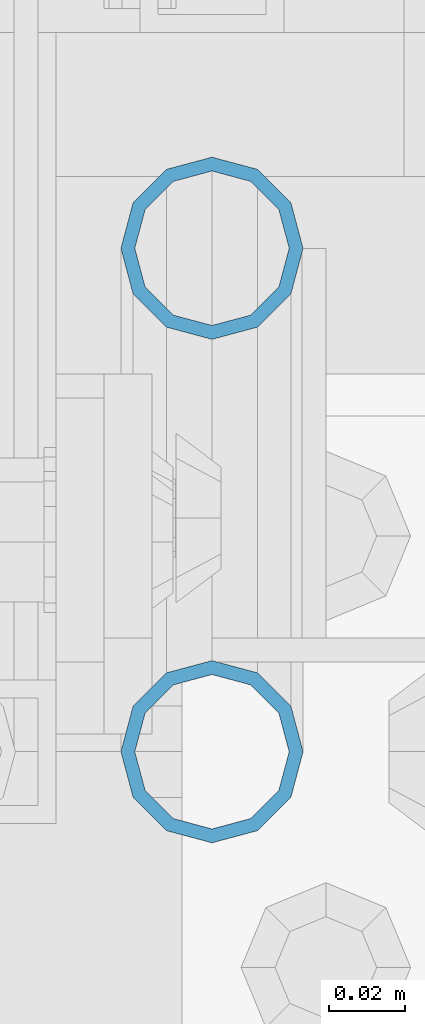
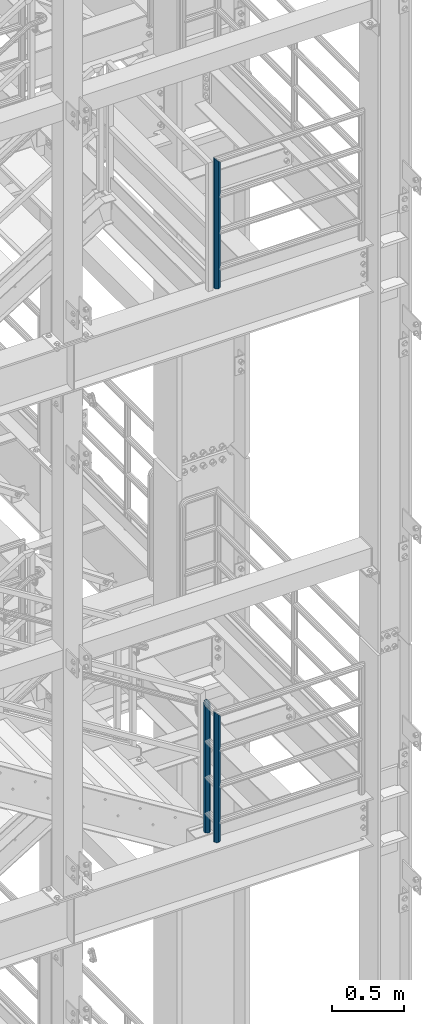
# One storey, part 585 of 1876: 3 columns, 2 elements without a shape of their own.
"""IFC2X3 building model written with IfcOpenShell, lengths in millimetres."""

from ifc_helpers import new_model, si_unit, frame, origin_with_axes, place, context, subcontext, project, spatial, faceted_brep, material, type_object, element, aggregate, save


model = new_model("IFC2X3")

# Units and contexts
model_context = context("Model", 3, precision=1e-05, world=origin_with_axes())
body_context = subcontext(model_context, "Body", "Model", "MODEL_VIEW")
ifc_project = project(units=[si_unit("LENGTHUNIT", "METRE", prefix="MILLI"), si_unit("AREAUNIT", "SQUARE_METRE"), si_unit("VOLUMEUNIT", "CUBIC_METRE"), si_unit("MASSUNIT", "GRAM", prefix="KILO"), si_unit("TIMEUNIT", "SECOND"), si_unit("PLANEANGLEUNIT", "RADIAN"), si_unit("SOLIDANGLEUNIT", "STERADIAN"), si_unit("THERMODYNAMICTEMPERATUREUNIT", "DEGREE_CELSIUS"), si_unit("LUMINOUSINTENSITYUNIT", "LUMEN")], contexts=[model_context])

# Site, building, storey
site_placement = place(None, origin_with_axes())
site = spatial("IfcSite", under=ifc_project, at=site_placement, CompositionType="ELEMENT")
building_placement = place(site_placement, origin_with_axes())
building = spatial("IfcBuilding", under=site, at=building_placement, Name="Undefined", CompositionType="ELEMENT")
storey_placement = place(building_placement, origin_with_axes())
storey = spatial("IfcBuildingStorey", under=building, at=storey_placement, Name="Undefined", CompositionType="ELEMENT", Elevation=0.0)

# Assembly, column
assembly_1_placement = place(storey_placement, origin_with_axes())
assembly_1 = element("IfcElementAssembly", 1, at=assembly_1_placement, inside=storey, Name="RAIL", AssemblyPlace="NOTDEFINED", PredefinedType="RIGID_FRAME")
ifc_material = material()
column_type = type_object("IfcColumnType", Name="PIPE1-1/2SCH40", PredefinedType="NOTDEFINED")
column_1_placement = place(assembly_1_placement, frame((6273.80016410903, -7112.0, 17983.2), z_axis=(0.0, 1.0, 0.0), x_axis=(0.0, 0.0, 1.0)))
column_1 = element("IfcColumn", 2, at=column_1_placement, type_object=column_type, material=ifc_material, Name="POST", ObjectType="PIPE1-1/2SCH40", context=body_context, shape_type="Brep", body=[
    faceted_brep([(0.0, -20.4469999999999, 0.0), (0.0, -17.7076214311803, 10.2235000000001), (1094.03262143118, -17.7076214311804, 10.2235000000001), (1096.772, -20.447, 0.0), (0.0, -10.2235000000001, 17.7076214311801), (1086.5485, -10.2235, 17.7076214311801), (-1.45519152283669e-11, 0.0, 20.4470000000001), (1076.325, 0.0, 20.4470000000001), (0.0, 10.2235000000001, 17.7076214311801), (1066.1015, 10.2235, 17.7076214311801), (0.0, 17.7076214311803, 10.2235000000001), (1058.61737856882, 17.7076214311804, 10.2235000000001), (0.0, 20.4469999999999, 0.0), (1055.878, 20.447, 0.0), (0.0, 17.7076214311803, -10.2235000000001), (1058.61737856882, 17.7076214311804, -10.2235000000001), (0.0, 10.2235000000001, -17.7076214311801), (1066.1015, 10.2235, -17.7076214311801), (-1.45519152283669e-11, 0.0, -20.4470000000001), (1076.325, 0.0, -20.4470000000001), (0.0, -10.2235000000001, -17.7076214311801), (1086.5485, -10.2235, -17.7076214311801), (0.0, -17.7076214311803, -10.2235000000001), (1094.03262143118, -17.7076214311804, -10.2235000000001), (0.0, -24.1299999999992, 0.0), (0.0, -20.8971929933184, -12.0649999999996), (1097.22219299332, -20.8971929933185, -12.0649999999996), (1100.455, -24.13, 0.0), (0.0, -12.0650000000001, -20.8971929933186), (1088.39, -12.065, -20.8971929933186), (-1.45519152283669e-11, 0.0, -24.130000000001), (1076.325, 0.0, -24.1300000000001), (0.0, 12.0650000000001, -20.8971929933186), (1064.26, 12.065, -20.8971929933186), (0.0, 20.8971929933184, -12.0649999999996), (1055.42780700668, 20.8971929933185, -12.0649999999996), (0.0, 24.1299999999992, 0.0), (1052.195, 24.13, 0.0), (0.0, 20.8971929933184, 12.0649999999996), (1055.42780700668, 20.8971929933185, 12.0649999999996), (0.0, 12.0650000000001, 20.8971929933186), (1064.26, 12.065, 20.8971929933186), (-1.45519152283669e-11, 0.0, 24.130000000001), (1076.325, 0.0, 24.1300000000001), (0.0, -12.0650000000001, 20.8971929933186), (1088.39, -12.065, 20.8971929933186), (0.0, -20.8971929933184, 12.0649999999996), (1097.22219299332, -20.8971929933185, 12.0649999999996)], [[[0, 1, 2, 3]], [[1, 4, 5, 2]], [[4, 6, 7, 5]], [[6, 8, 9, 7]], [[8, 10, 11, 9]], [[10, 12, 13, 11]], [[12, 14, 15, 13]], [[14, 16, 17, 15]], [[16, 18, 19, 17]], [[18, 20, 21, 19]], [[20, 22, 23, 21]], [[22, 0, 3, 23]], [[24, 25, 26, 27]], [[25, 28, 29, 26]], [[28, 30, 31, 29]], [[30, 32, 33, 31]], [[32, 34, 35, 33]], [[34, 36, 37, 35]], [[36, 38, 39, 37]], [[38, 40, 41, 39]], [[40, 42, 43, 41]], [[42, 44, 45, 43]], [[44, 46, 47, 45]], [[46, 24, 27, 47]], [[29, 31, 33, 35, 37, 39, 41, 43, 45, 47, 27, 26], [5, 7, 9, 11, 13, 15, 17, 19, 21, 23, 3, 2]], [[46, 44, 42, 40, 38, 36, 34, 32, 30, 28, 25, 24], [22, 20, 18, 16, 14, 12, 10, 8, 6, 4, 1, 0]]]),
])
aggregate(assembly_1, [column_1])

# Assembly, columns
assembly_2_placement = place(storey_placement, origin_with_axes())
assembly_2 = element("IfcElementAssembly", 3, at=assembly_2_placement, inside=storey, Name="RAIL", AssemblyPlace="NOTDEFINED", PredefinedType="RIGID_FRAME")
column_2_placement = place(assembly_2_placement, frame((6273.80016410903, -6978.65, 13309.6), z_axis=(0.0, 1.0, 0.0), x_axis=(0.0, 0.0, 1.0)))
column_2 = element("IfcColumn", 4, at=column_2_placement, type_object=column_type, material=ifc_material, Name="POST", ObjectType="PIPE1-1/2SCH40", context=body_context, shape_type="Brep", body=[
    faceted_brep([(0.0, -20.4469999999999, 0.0), (0.0, -17.7076214311803, 10.2235000000001), (1086.54849999999, -17.7076214311801, 10.2235000000001), (1076.325, -20.4469999999999, 0.0), (0.0, -10.2235000000001, 17.7076214311801), (1094.03262143117, -10.2235000000001, 17.7076214311801), (-1.45519152283669e-11, 0.0, 20.4470000000001), (1096.77199999999, 0.0, 20.4470000000001), (0.0, 10.2235000000001, 17.7076214311801), (1094.03262143117, 10.2235000000001, 17.7076214311801), (0.0, 17.7076214311803, 10.2235000000001), (1086.54849999999, 17.7076214311801, 10.2235000000001), (0.0, 20.4469999999999, 0.0), (1076.325, 20.4469999999999, 0.0), (0.0, 17.7076214311803, -10.2235000000001), (1066.10149999999, 17.7076214311801, -10.2235000000001), (0.0, 10.2235000000001, -17.7076214311801), (1058.61737856881, 10.2235000000001, -17.7076214311801), (-1.45519152283669e-11, 0.0, -20.4470000000001), (1055.87799999999, 0.0, -20.4470000000001), (0.0, -10.2235000000001, -17.7076214311801), (1058.61737856881, -10.2235000000001, -17.7076214311801), (0.0, -17.7076214311803, -10.2235000000001), (1066.10149999999, -17.7076214311801, -10.2235000000001), (0.0, -24.1299999999992, 0.0), (0.0, -20.8971929933184, -12.0649999999996), (1064.25999999999, -20.8971929933186, -12.0649999999996), (1076.325, -24.1300000000001, 0.0), (0.0, -12.0650000000001, -20.8971929933186), (1055.42780700667, -12.0649999999996, -20.8971929933186), (-1.45519152283669e-11, 0.0, -24.130000000001), (1052.19499999999, 0.0, -24.1300000000001), (0.0, 12.0650000000001, -20.8971929933186), (1055.42780700667, 12.0649999999996, -20.8971929933186), (0.0, 20.8971929933184, -12.0649999999996), (1064.25999999999, 20.8971929933186, -12.0649999999996), (0.0, 24.1299999999992, 0.0), (1076.325, 24.1300000000001, 0.0), (0.0, 20.8971929933184, 12.0649999999996), (1088.38999999999, 20.8971929933186, 12.0649999999996), (0.0, 12.0650000000001, 20.8971929933186), (1097.22219299331, 12.0649999999996, 20.8971929933186), (-1.45519152283669e-11, 0.0, 24.130000000001), (1100.45499999999, 0.0, 24.1300000000001), (0.0, -12.0650000000001, 20.8971929933186), (1097.22219299331, -12.0649999999996, 20.8971929933186), (0.0, -20.8971929933184, 12.0649999999996), (1088.38999999999, -20.8971929933186, 12.0649999999996)], [[[0, 1, 2, 3]], [[1, 4, 5, 2]], [[4, 6, 7, 5]], [[6, 8, 9, 7]], [[8, 10, 11, 9]], [[10, 12, 13, 11]], [[12, 14, 15, 13]], [[14, 16, 17, 15]], [[16, 18, 19, 17]], [[18, 20, 21, 19]], [[20, 22, 23, 21]], [[22, 0, 3, 23]], [[24, 25, 26, 27]], [[25, 28, 29, 26]], [[28, 30, 31, 29]], [[30, 32, 33, 31]], [[32, 34, 35, 33]], [[34, 36, 37, 35]], [[36, 38, 39, 37]], [[38, 40, 41, 39]], [[40, 42, 43, 41]], [[42, 44, 45, 43]], [[44, 46, 47, 45]], [[46, 24, 27, 47]], [[29, 31, 33, 35, 37, 39, 41, 43, 45, 47, 27, 26], [5, 7, 9, 11, 13, 15, 17, 19, 21, 23, 3, 2]], [[46, 44, 42, 40, 38, 36, 34, 32, 30, 28, 25, 24], [22, 20, 18, 16, 14, 12, 10, 8, 6, 4, 1, 0]]]),
])
column_3_placement = place(assembly_2_placement, frame((6273.80016410903, -7112.0, 13309.6), z_axis=(0.0, 1.0, 0.0), x_axis=(0.0, 0.0, 1.0)))
column_3 = element("IfcColumn", 5, at=column_3_placement, type_object=column_type, material=ifc_material, Name="POST", ObjectType="PIPE1-1/2SCH40", context=body_context, shape_type="Brep", body=[
    faceted_brep([(0.0, -20.4469999999999, 0.0), (0.0, -17.7076214311803, 10.2235000000001), (1094.03262143118, -17.7076214311804, 10.2235000000001), (1096.772, -20.447, 0.0), (0.0, -10.2235000000001, 17.7076214311801), (1086.5485, -10.2235, 17.7076214311801), (-1.45519152283669e-11, 0.0, 20.4470000000001), (1076.325, 0.0, 20.4470000000001), (0.0, 10.2235000000001, 17.7076214311801), (1066.1015, 10.2235, 17.7076214311801), (0.0, 17.7076214311803, 10.2235000000001), (1058.61737856882, 17.7076214311804, 10.2235000000001), (0.0, 20.4469999999999, 0.0), (1055.878, 20.447, 0.0), (0.0, 17.7076214311803, -10.2235000000001), (1058.61737856882, 17.7076214311804, -10.2235000000001), (0.0, 10.2235000000001, -17.7076214311801), (1066.1015, 10.2235, -17.7076214311801), (-1.45519152283669e-11, 0.0, -20.4470000000001), (1076.325, 0.0, -20.4470000000001), (0.0, -10.2235000000001, -17.7076214311801), (1086.5485, -10.2235, -17.7076214311801), (0.0, -17.7076214311803, -10.2235000000001), (1094.03262143118, -17.7076214311804, -10.2235000000001), (0.0, -24.1299999999992, 0.0), (0.0, -20.8971929933184, -12.0649999999996), (1097.22219299332, -20.8971929933185, -12.0649999999996), (1100.455, -24.13, 0.0), (0.0, -12.0650000000001, -20.8971929933186), (1088.39, -12.065, -20.8971929933186), (-1.45519152283669e-11, 0.0, -24.130000000001), (1076.325, 0.0, -24.1300000000001), (0.0, 12.0650000000001, -20.8971929933186), (1064.26, 12.065, -20.8971929933186), (0.0, 20.8971929933184, -12.0649999999996), (1055.42780700668, 20.8971929933185, -12.0649999999996), (0.0, 24.1299999999992, 0.0), (1052.195, 24.13, 0.0), (0.0, 20.8971929933184, 12.0649999999996), (1055.42780700668, 20.8971929933185, 12.0649999999996), (0.0, 12.0650000000001, 20.8971929933186), (1064.26, 12.065, 20.8971929933186), (-1.45519152283669e-11, 0.0, 24.130000000001), (1076.325, 0.0, 24.1300000000001), (0.0, -12.0650000000001, 20.8971929933186), (1088.39, -12.065, 20.8971929933186), (0.0, -20.8971929933184, 12.0649999999996), (1097.22219299332, -20.8971929933185, 12.0649999999996)], [[[0, 1, 2, 3]], [[1, 4, 5, 2]], [[4, 6, 7, 5]], [[6, 8, 9, 7]], [[8, 10, 11, 9]], [[10, 12, 13, 11]], [[12, 14, 15, 13]], [[14, 16, 17, 15]], [[16, 18, 19, 17]], [[18, 20, 21, 19]], [[20, 22, 23, 21]], [[22, 0, 3, 23]], [[24, 25, 26, 27]], [[25, 28, 29, 26]], [[28, 30, 31, 29]], [[30, 32, 33, 31]], [[32, 34, 35, 33]], [[34, 36, 37, 35]], [[36, 38, 39, 37]], [[38, 40, 41, 39]], [[40, 42, 43, 41]], [[42, 44, 45, 43]], [[44, 46, 47, 45]], [[46, 24, 27, 47]], [[29, 31, 33, 35, 37, 39, 41, 43, 45, 47, 27, 26], [5, 7, 9, 11, 13, 15, 17, 19, 21, 23, 3, 2]], [[46, 44, 42, 40, 38, 36, 34, 32, 30, 28, 25, 24], [22, 20, 18, 16, 14, 12, 10, 8, 6, 4, 1, 0]]]),
])
aggregate(assembly_2, [column_2, column_3])

save(model, "model.ifc")
